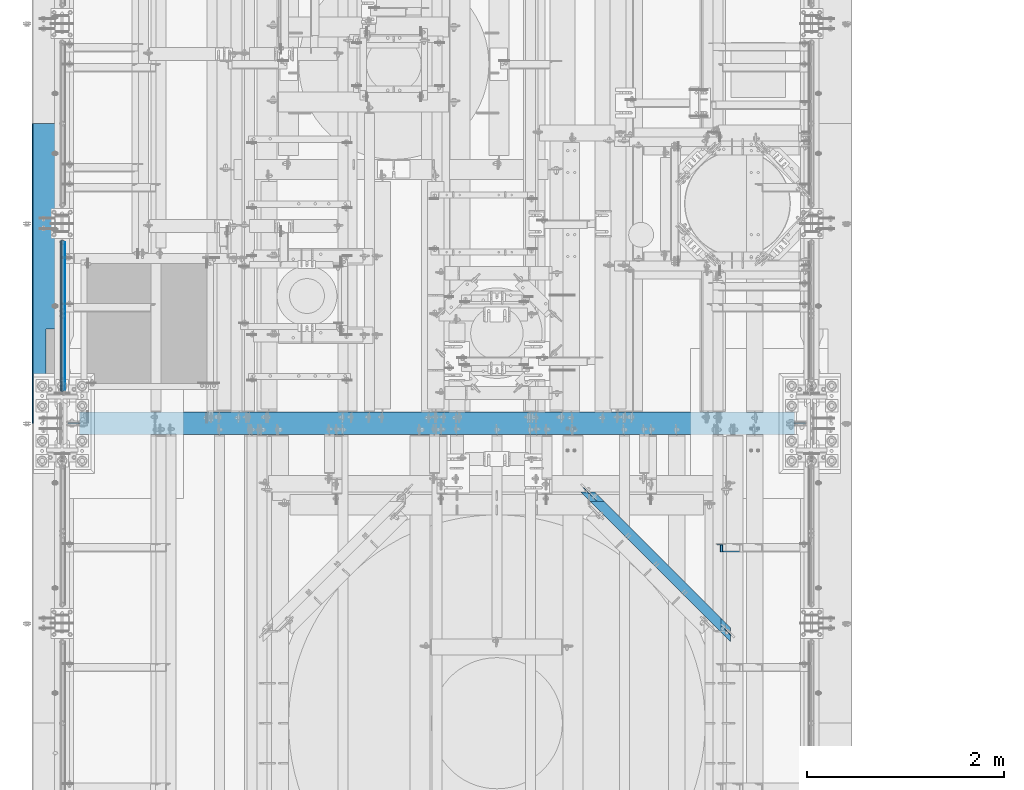
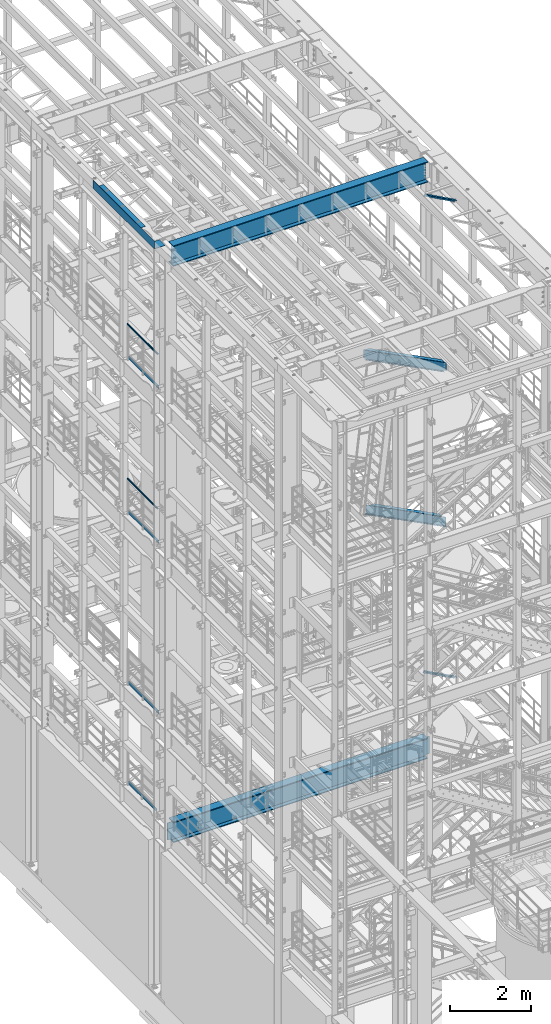
# One storey, part 1015 of 1876: 11 beams, 2 members, 11 elements without a shape of their own.
"""IFC2X3 building model written with IfcOpenShell, lengths in millimetres."""

from ifc_helpers import new_model, si_unit, frame, origin_with_axes, place, context, subcontext, project, spatial, faceted_brep, material, type_object, element, aggregate, save


model = new_model("IFC2X3")

# Units and contexts
model_context = context("Model", 3, precision=1e-05, world=origin_with_axes())
body_context = subcontext(model_context, "Body", "Model", "MODEL_VIEW")
ifc_project = project(units=[si_unit("LENGTHUNIT", "METRE", prefix="MILLI"), si_unit("AREAUNIT", "SQUARE_METRE"), si_unit("VOLUMEUNIT", "CUBIC_METRE"), si_unit("MASSUNIT", "GRAM", prefix="KILO"), si_unit("TIMEUNIT", "SECOND"), si_unit("PLANEANGLEUNIT", "RADIAN"), si_unit("SOLIDANGLEUNIT", "STERADIAN"), si_unit("THERMODYNAMICTEMPERATUREUNIT", "DEGREE_CELSIUS"), si_unit("LUMINOUSINTENSITYUNIT", "LUMEN")], contexts=[model_context])

# Site, building, storey
site_placement = place(None, origin_with_axes())
site = spatial("IfcSite", under=ifc_project, at=site_placement, CompositionType="ELEMENT")
building_placement = place(site_placement, origin_with_axes())
building = spatial("IfcBuilding", under=site, at=building_placement, Name="Undefined", CompositionType="ELEMENT")
storey_placement = place(building_placement, origin_with_axes())
storey = spatial("IfcBuildingStorey", under=building, at=storey_placement, Name="Undefined", CompositionType="ELEMENT", Elevation=0.0)

# Assembly, beam
assembly_1_placement = place(storey_placement, origin_with_axes())
assembly_1 = element("IfcElementAssembly", 1, at=assembly_1_placement, inside=storey, Name="RAIL", AssemblyPlace="NOTDEFINED", PredefinedType="RIGID_FRAME")
ifc_material_1 = material()
beam_type_1 = type_object("IfcBeamType", Name="PIPE1-1/2SCH40", PredefinedType="NOTDEFINED")
beam_1_placement = place(assembly_1_placement, frame((-1.81898940354586e-12, 1844.675, 19059.525), z_axis=(0.0, 0.0, -1.0), x_axis=(0.0, 1.0, 0.0)))
beam_1 = element("IfcBeam", 2, at=beam_1_placement, type_object=beam_type_1, material=ifc_material_1, Name="RAIL", ObjectType="PIPE1-1/2SCH40", context=body_context, shape_type="Brep", body=[
    faceted_brep([(24.1300000000001, -20.4469999999999, 0.0), (34.3535000000002, -17.7076214311803, 10.2235000000001), (1511.8715, -17.7076214311801, 10.2235000000001), (1522.095, -20.4470000000001, 0.0), (41.8376214311802, -10.2235000000001, 17.7076214311819), (1504.38737856882, -10.2235000000001, 17.7076214311819), (44.5770000000002, 0.0, 20.4470000000001), (1501.648, 0.0, 20.4470000000001), (41.8376214311802, 10.2235000000001, 17.7076214311819), (1504.38737856882, 10.2235000000001, 17.7076214311819), (34.3535000000002, 17.7076214311803, 10.2235000000001), (1511.8715, 17.7076214311801, 10.2235000000001), (24.1300000000001, 20.4469999999999, 0.0), (1522.095, 20.4470000000001, 0.0), (13.9065000000001, 17.7076214311803, -10.2235000000001), (1532.3185, 17.7076214311801, -10.2235000000001), (6.42237856882002, 10.2235000000001, -17.7076214311819), (1539.80262143118, 10.2235000000001, -17.7076214311819), (3.68299999999999, 0.0, -20.4470000000001), (1542.542, 0.0, -20.4470000000001), (6.42237856882002, -10.2235000000001, -17.7076214311819), (1539.80262143118, -10.2235000000001, -17.7076214311819), (13.9065000000001, -17.7076214311803, -10.2235000000001), (1532.3185, -17.7076214311801, -10.2235000000001), (24.1299999999854, -24.1299999999992, 0.0), (12.0650000000064, -20.8971929933177, -12.0649999999987), (1534.16, -20.8971929933186, -12.0649999999987), (1522.095, -24.1300000000001, 0.0), (3.23280700668147, -12.0650000000001, -20.8971929933177), (1542.99219299332, -12.0649999999996, -20.8971929933177), (-1.45519152283669e-11, 0.0, -24.130000000001), (1546.225, 0.0, -24.130000000001), (3.23280700668147, 12.0650000000001, -20.8971929933177), (1542.99219299332, 12.0649999999996, -20.8971929933177), (12.0650000000064, 20.8971929933177, -12.0649999999987), (1534.16, 20.8971929933186, -12.0649999999987), (24.1300000000047, 24.1299999999992, 0.0), (1522.095, 24.1300000000001, 0.0), (36.1949999999997, 20.8971929933184, 12.0649999999987), (1510.03, 20.8971929933186, 12.0649999999987), (45.0271929933187, 12.0650000000001, 20.8971929933177), (1501.19780700668, 12.0649999999996, 20.8971929933177), (48.2600000000002, 0.0, 24.130000000001), (1497.965, 0.0, 24.130000000001), (45.0271929933187, -12.0650000000001, 20.8971929933177), (1501.19780700668, -12.0649999999996, 20.8971929933177), (36.1949999999997, -20.8971929933184, 12.0649999999987), (1510.03, -20.8971929933186, 12.0649999999987)], [[[0, 1, 2, 3]], [[1, 4, 5, 2]], [[4, 6, 7, 5]], [[6, 8, 9, 7]], [[8, 10, 11, 9]], [[10, 12, 13, 11]], [[12, 14, 15, 13]], [[14, 16, 17, 15]], [[16, 18, 19, 17]], [[18, 20, 21, 19]], [[20, 22, 23, 21]], [[22, 0, 3, 23]], [[24, 25, 26, 27]], [[25, 28, 29, 26]], [[28, 30, 31, 29]], [[30, 32, 33, 31]], [[32, 34, 35, 33]], [[34, 36, 37, 35]], [[36, 38, 39, 37]], [[38, 40, 41, 39]], [[40, 42, 43, 41]], [[42, 44, 45, 43]], [[44, 46, 47, 45]], [[46, 24, 27, 47]], [[29, 31, 33, 35, 37, 39, 41, 43, 45, 47, 27, 26], [5, 7, 9, 11, 13, 15, 17, 19, 21, 23, 3, 2]], [[46, 44, 42, 40, 38, 36, 34, 32, 30, 28, 25, 24], [22, 20, 18, 16, 14, 12, 10, 8, 6, 4, 1, 0]]]),
])

assembly_2_placement = place(storey_placement, origin_with_axes())
assembly_2 = element("IfcElementAssembly", 3, at=assembly_2_placement, inside=storey, Name="RAIL", AssemblyPlace="NOTDEFINED", PredefinedType="RIGID_FRAME")
beam_2_placement = place(assembly_2_placement, frame((-1.81898940354586e-12, 1844.675, 14385.925), z_axis=(0.0, 0.0, -1.0), x_axis=(0.0, 1.0, 0.0)))
beam_2 = element("IfcBeam", 4, at=beam_2_placement, type_object=beam_type_1, material=ifc_material_1, Name="RAIL", ObjectType="PIPE1-1/2SCH40", context=body_context, shape_type="Brep", body=[
    faceted_brep([(24.1300000000001, -20.4469999999999, 0.0), (34.3535000000002, -17.7076214311803, 10.2235000000001), (1511.8715, -17.7076214311801, 10.2235000000001), (1522.095, -20.4470000000001, 0.0), (41.8376214311802, -10.2235000000001, 17.7076214311819), (1504.38737856882, -10.2235000000001, 17.7076214311819), (44.5770000000002, 0.0, 20.4470000000001), (1501.648, 0.0, 20.4470000000001), (41.8376214311802, 10.2235000000001, 17.7076214311819), (1504.38737856882, 10.2235000000001, 17.7076214311819), (34.3535000000002, 17.7076214311803, 10.2235000000001), (1511.8715, 17.7076214311801, 10.2235000000001), (24.1300000000001, 20.4469999999999, 0.0), (1522.095, 20.4470000000001, 0.0), (13.9065000000001, 17.7076214311803, -10.2235000000001), (1532.3185, 17.7076214311801, -10.2235000000001), (6.42237856882002, 10.2235000000001, -17.7076214311819), (1539.80262143118, 10.2235000000001, -17.7076214311819), (3.68299999999999, 0.0, -20.4470000000001), (1542.542, 0.0, -20.4470000000001), (6.42237856882002, -10.2235000000001, -17.7076214311819), (1539.80262143118, -10.2235000000001, -17.7076214311819), (13.9065000000001, -17.7076214311803, -10.2235000000001), (1532.3185, -17.7076214311801, -10.2235000000001), (24.1299999999854, -24.1299999999992, 0.0), (12.0650000000064, -20.8971929933177, -12.0649999999987), (1534.16, -20.8971929933186, -12.0649999999987), (1522.095, -24.1300000000001, 0.0), (3.23280700668147, -12.0650000000001, -20.8971929933177), (1542.99219299332, -12.0649999999996, -20.8971929933177), (-1.45519152283669e-11, 0.0, -24.130000000001), (1546.225, 0.0, -24.130000000001), (3.23280700668147, 12.0650000000001, -20.8971929933177), (1542.99219299332, 12.0649999999996, -20.8971929933177), (12.0650000000064, 20.8971929933177, -12.0649999999987), (1534.16, 20.8971929933186, -12.0649999999987), (24.1300000000047, 24.1299999999992, 0.0), (1522.095, 24.1300000000001, 0.0), (36.1949999999997, 20.8971929933184, 12.0649999999987), (1510.03, 20.8971929933186, 12.0649999999987), (45.0271929933187, 12.0650000000001, 20.8971929933177), (1501.19780700668, 12.0649999999996, 20.8971929933177), (48.2600000000002, 0.0, 24.130000000001), (1497.965, 0.0, 24.130000000001), (45.0271929933187, -12.0650000000001, 20.8971929933177), (1501.19780700668, -12.0649999999996, 20.8971929933177), (36.1949999999997, -20.8971929933184, 12.0649999999987), (1510.03, -20.8971929933186, 12.0649999999987)], [[[0, 1, 2, 3]], [[1, 4, 5, 2]], [[4, 6, 7, 5]], [[6, 8, 9, 7]], [[8, 10, 11, 9]], [[10, 12, 13, 11]], [[12, 14, 15, 13]], [[14, 16, 17, 15]], [[16, 18, 19, 17]], [[18, 20, 21, 19]], [[20, 22, 23, 21]], [[22, 0, 3, 23]], [[24, 25, 26, 27]], [[25, 28, 29, 26]], [[28, 30, 31, 29]], [[30, 32, 33, 31]], [[32, 34, 35, 33]], [[34, 36, 37, 35]], [[36, 38, 39, 37]], [[38, 40, 41, 39]], [[40, 42, 43, 41]], [[42, 44, 45, 43]], [[44, 46, 47, 45]], [[46, 24, 27, 47]], [[29, 31, 33, 35, 37, 39, 41, 43, 45, 47, 27, 26], [5, 7, 9, 11, 13, 15, 17, 19, 21, 23, 3, 2]], [[46, 44, 42, 40, 38, 36, 34, 32, 30, 28, 25, 24], [22, 20, 18, 16, 14, 12, 10, 8, 6, 4, 1, 0]]]),
])

# Beam
ifc_material_2 = material(Name="STEEL/A36")
beam_type_2 = type_object("IfcBeamType", PredefinedType="NOTDEFINED")
beam_3_placement = place(assembly_1_placement, frame((27.3049999999948, 1868.805, 18049.875), z_axis=(0.0, 0.0, 1.0), x_axis=(0.0, 1.0, 0.0)))
beam_3 = element("IfcBeam", 5, at=beam_3_placement, type_object=beam_type_2, material=ifc_material_2, Name="PLATE", context=body_context, shape_type="Brep", body=[
    faceted_brep([(0.0, 3.17500000000018, -50.8000000000002), (0.0, 3.17500000000018, 50.8000000000002), (1497.965, 3.175, 50.7999999999993), (1497.965, 3.175, -50.7999999999993), (0.0, -3.17500000000018, 50.8000000000002), (1497.965, -3.175, 50.7999999999993), (0.0, -3.17500000000018, -50.8000000000002), (1497.965, -3.175, -50.7999999999993)], [[[0, 1, 2, 3]], [[1, 4, 5, 2]], [[4, 6, 7, 5]], [[6, 0, 3, 7]], [[5, 7, 3, 2]], [[6, 4, 1, 0]]]),
])

aggregate(assembly_1, [beam_3, beam_1])

beam_4_placement = place(assembly_2_placement, frame((27.3049999999948, 1868.805, 13376.275), z_axis=(0.0, 0.0, 1.0), x_axis=(0.0, 1.0, 0.0)))
beam_4 = element("IfcBeam", 6, at=beam_4_placement, type_object=beam_type_2, material=ifc_material_2, Name="PLATE", context=body_context, shape_type="Brep", body=[
    faceted_brep([(0.0, 3.17500000000018, -50.8000000000002), (0.0, 3.17500000000018, 50.8000000000002), (1497.965, 3.175, 50.7999999999993), (1497.965, 3.175, -50.7999999999993), (0.0, -3.17500000000018, 50.8000000000002), (1497.965, -3.175, 50.7999999999993), (0.0, -3.17500000000018, -50.8000000000002), (1497.965, -3.175, -50.7999999999993)], [[[0, 1, 2, 3]], [[1, 4, 5, 2]], [[4, 6, 7, 5]], [[6, 0, 3, 7]], [[5, 7, 3, 2]], [[6, 4, 1, 0]]]),
])

aggregate(assembly_2, [beam_4, beam_2])

# Assembly, beam
assembly_3_placement = place(storey_placement, origin_with_axes())
assembly_3 = element("IfcElementAssembly", 7, at=assembly_3_placement, inside=storey, Name="RAIL", AssemblyPlace="NOTDEFINED", PredefinedType="RIGID_FRAME")
beam_5_placement = place(assembly_3_placement, frame((27.3049999999948, 1868.805, 8220.07500000001), z_axis=(0.0, 0.0, 1.0), x_axis=(0.0, 1.0, 0.0)))
beam_5 = element("IfcBeam", 8, at=beam_5_placement, type_object=beam_type_2, material=ifc_material_2, Name="PLATE", context=body_context, shape_type="Brep", body=[
    faceted_brep([(0.0, 3.17500000000018, -50.8000000000002), (0.0, 3.17500000000018, 50.8000000000002), (1497.965, 3.175, 50.7999999999993), (1497.965, 3.175, -50.7999999999993), (0.0, -3.17500000000018, 50.8000000000002), (1497.965, -3.175, 50.7999999999993), (0.0, -3.17500000000018, -50.8000000000002), (1497.965, -3.175, -50.7999999999993)], [[[0, 1, 2, 3]], [[1, 4, 5, 2]], [[4, 6, 7, 5]], [[6, 0, 3, 7]], [[5, 7, 3, 2]], [[6, 4, 1, 0]]]),
])
aggregate(assembly_3, [beam_5])

assembly_4_placement = place(storey_placement, origin_with_axes())
assembly_4 = element("IfcElementAssembly", 9, at=assembly_4_placement, inside=storey, Name="RAIL", AssemblyPlace="NOTDEFINED", PredefinedType="RIGID_FRAME")
beam_6_placement = place(assembly_4_placement, frame((27.3049999999948, 1964.05499999999, 5197.475), z_axis=(0.0, 0.0, 1.0), x_axis=(0.0, 1.0, 0.0)))
beam_6 = element("IfcBeam", 10, at=beam_6_placement, type_object=beam_type_2, material=ifc_material_2, Name="PLATE", context=body_context, shape_type="Brep", body=[
    faceted_brep([(0.0, 3.17500000000018, -50.8000000000002), (0.0, 3.17500000000018, 50.8000000000002), (1402.715, 3.175, 50.8000000000002), (1402.715, 3.175, -50.8000000000002), (0.0, -3.17500000000018, 50.8000000000002), (1402.715, -3.175, 50.8000000000002), (0.0, -3.17500000000018, -50.8000000000002), (1402.715, -3.175, -50.8000000000002)], [[[0, 1, 2, 3]], [[1, 4, 5, 2]], [[4, 6, 7, 5]], [[6, 0, 3, 7]], [[5, 7, 3, 2]], [[6, 4, 1, 0]]]),
])
aggregate(assembly_4, [beam_6])

# Assembly, member
assembly_5_placement = place(storey_placement, origin_with_axes())
assembly_5 = element("IfcElementAssembly", 11, at=assembly_5_placement, inside=storey, AssemblyPlace="NOTDEFINED", PredefinedType="RIGID_FRAME")
member_type = type_object("IfcMemberType", Name="L3X3X3/8", PredefinedType="NOTDEFINED")
member_1_placement = place(assembly_5_placement, frame((6613.42656309324, 257.174999999997, 8122.54466495056), z_axis=(0.0, -1.0, 0.0), x_axis=(0.882670061850832, 0.0, -0.469993150920573)))
member_1 = element("IfcMember", 12, at=member_1_placement, type_object=member_type, material=ifc_material_2, ObjectType="L3X3X3/8", context=body_context, shape_type="Brep", body=[
    faceted_brep([(70.0788597189262, 38.1000000000258, -38.1), (70.0788597189262, 38.1000000000258, 38.1), (1091.31003699859, 38.1000000003387, 38.1), (1091.31003699859, 38.1000000003387, -38.1), (70.0788597189253, 28.5750000000244, 38.1), (1091.31003699859, 28.5750000003391, 38.1), (70.0788597189253, 28.5750000000244, -28.575), (1091.31003699859, 28.5750000003391, -28.575), (70.0788597189262, -38.0999999999822, -28.575), (1091.31003699859, -38.0999999996675, -28.575), (70.0788597189262, -38.0999999999822, -38.1), (1091.31003699859, -38.0999999996675, -38.1)], [[[0, 1, 2, 3]], [[1, 4, 5, 2]], [[4, 6, 7, 5]], [[6, 8, 9, 7]], [[8, 10, 11, 9]], [[10, 0, 3, 11]], [[5, 7, 9, 11, 3, 2]], [[10, 8, 6, 4, 1, 0]]]),
])
aggregate(assembly_5, [member_1])

assembly_6_placement = place(storey_placement, origin_with_axes())
assembly_6 = element("IfcElementAssembly", 13, at=assembly_6_placement, inside=storey, AssemblyPlace="NOTDEFINED", PredefinedType="RIGID_FRAME")
member_2_placement = place(assembly_6_placement, frame((6649.22451200435, 257.174999999997, 22521.7692276093), z_axis=(0.0, -1.0, 0.0), x_axis=(0.877448093107094, 0.0, -0.479671600058544)))
member_2 = element("IfcMember", 14, at=member_2_placement, type_object=member_type, material=ifc_material_2, ObjectType="L3X3X3/8", context=body_context, shape_type="Brep", body=[
    faceted_brep([(59.7482362440578, 38.0999999998749, -38.0999999999999), (59.7482362440578, 38.0999999998749, 38.0999999999999), (1062.91900040893, 38.0999999984488, 38.0999999999999), (1062.91900040893, 38.0999999984488, -38.0999999999999), (59.7482362440696, 28.5749999998843, 38.0999999999999), (1062.91900040895, 28.5749999984582, 38.0999999999999), (59.7482362440696, 28.5749999998843, -28.5749999999998), (1062.91900040895, 28.5749999984582, -28.5749999999998), (59.7482362441442, -38.1000000000495, -28.5749999999998), (1062.91900040902, -38.1000000014719, -28.5749999999998), (59.7482362441442, -38.1000000000495, -38.0999999999999), (1062.91900040902, -38.1000000014719, -38.0999999999999)], [[[0, 1, 2, 3]], [[1, 4, 5, 2]], [[4, 6, 7, 5]], [[6, 8, 9, 7]], [[8, 10, 11, 9]], [[10, 0, 3, 11]], [[5, 7, 9, 11, 3, 2]], [[10, 8, 6, 4, 1, 0]]]),
])
aggregate(assembly_6, [member_2])

# Assembly, beam
assembly_7_placement = place(storey_placement, origin_with_axes())
assembly_7 = element("IfcElementAssembly", 15, at=assembly_7_placement, inside=storey, Name="BEAM", AssemblyPlace="NOTDEFINED", PredefinedType="RIGID_FRAME")
ifc_material_3 = material(Name="STEEL/A992")
beam_type_3 = type_object("IfcBeamType", Name="W12X16", PredefinedType="NOTDEFINED")
beam_7_placement = place(assembly_7_placement, frame((6903.48911505469, -731.547206052242, 17830.8), z_axis=(0.0, 0.0, 1.0), x_axis=(-0.707106781186548, 0.707106781186547, 0.0)))
beam_7 = element("IfcBeam", 16, at=beam_7_placement, type_object=beam_type_3, material=ifc_material_3, Name="BEAM", ObjectType="W12X16", context=body_context, shape_type="Brep", body=[
    faceted_brep([(175.17619927822, 50.7999999999511, -152.400000000001), (175.17619927822, 50.7999999999511, -146.049999999999), (2239.32686272223, 50.7999999995645, -146.049999999999), (2239.32686272223, 50.7999999995645, -152.400000000001), (222.801200490549, 3.17499999995653, -146.049999999999), (2191.70186393459, 3.17499999958818, -146.049999999999), (2209.66237567833, 3.17499999958545, -131.762500000008), (2203.31237583998, -3.17500000041218, -131.762500000008), (2196.43918555883, -3.17500000041036, -132.729229922596), (2202.78918539718, 3.17499999958545, -132.729229922596), (2190.61237619236, -3.17500000040945, -135.482243823073), (2196.96237603071, 3.17499999958727, -135.482243823073), (2186.71902664645, -3.17500000040855, -139.602420291227), (2193.06902648481, 3.17499999958818, -139.602420291227), (2185.35186409618, -3.17500000040855, -144.462499809273), (2191.70186393453, 3.17499999958818, -144.462499809273), (229.151200652193, -3.17500000004202, -146.049999999999), (276.776201864521, -50.8000000000366, -146.049999999999), (2137.7268653086, -50.8000000003849, -146.049999999999), (2185.35186409624, -3.17500000040855, -146.049999999999), (276.776201864521, -50.8000000000366, -152.400000000001), (2137.7268653086, -50.8000000003849, -152.400000000001), (229.151200652176, -3.17500000004293, -144.46249980927), (222.80120049053, 3.17499999995653, -144.46249980927), (227.7840380671, -3.17500000004202, -139.602420291223), (221.434037905454, 3.17499999995653, -139.602420291223), (223.89068842209, -3.17500000004202, -135.482243823069), (217.540688260444, 3.17499999995744, -135.482243823069), (218.063878907296, -3.17500000004111, -132.729229922592), (211.713878745652, 3.17499999995835, -132.729229922592), (211.190688451187, -3.1750000000402, -131.762500000004), (204.840688289542, 3.17499999996016, -131.762500000004), (142.297997710428, -3.17499999997381, -131.762500000004), (142.297997710437, 3.17500000002565, -131.762500000004), (142.297997710428, -3.17499999997381, 123.825000000001), (142.297997710437, 3.17500000002565, 123.825000000001), (211.190688450936, -3.1750000000402, 123.825000000001), (204.840688289291, 3.17499999996016, 123.825000000001), (218.063878907045, -3.17500000004111, 124.791729922588), (211.713878745401, 3.17499999995835, 124.791729922588), (223.890688421839, -3.17500000004202, 127.544743823066), (217.540688260193, 3.17499999995744, 127.544743823066), (227.784038066849, -3.17500000004202, 131.664920291219), (221.434037905203, 3.17499999995653, 131.664920291219), (229.151200651925, -3.17500000004293, 136.524999809266), (222.801200490279, 3.17499999995653, 136.524999809266), (2239.32686272236, 50.7999999995645, 152.400000000001), (2239.32686272236, 50.7999999995645, 146.049999999999), (175.176199277891, 50.7999999999502, 146.049999999999), (175.176199277891, 50.7999999999502, 152.400000000001), (2137.72686530873, -50.8000000003849, 152.400000000001), (276.776201864192, -50.8000000000366, 152.400000000001), (2137.72686530873, -50.8000000003849, 146.049999999999), (276.776201864192, -50.8000000000366, 146.049999999999), (2185.35186409637, -3.17500000040855, 146.049999999999), (229.151200651863, -3.17500000004202, 146.049999999999), (222.801200490219, 3.17499999995653, 146.049999999999), (2191.70186393472, 3.17499999958818, 146.049999999999), (2185.35186409639, -3.17500000040764, 136.524999809262), (2191.70186393474, 3.17499999958818, 136.524999809262), (2186.71902664666, -3.17500000040855, 131.664920291216), (2193.06902648501, 3.17499999958727, 131.664920291216), (2190.61237619256, -3.17500000040945, 127.544743823062), (2196.96237603092, 3.17499999958727, 127.544743823062), (2196.43918555903, -3.17500000041036, 124.791729922585), (2202.78918539739, 3.17499999958636, 124.791729922585), (2203.31237584018, -3.17500000041218, 123.824999999997), (2209.66237567854, 3.17499999958454, 123.824999999997), (2272.20506418067, -3.17500000042401, 123.824999999997), (2272.20506418067, 3.17499999957363, 123.824999999997), (2272.20506418067, 3.17499999957363, -131.762500000008), (2272.20506418067, -3.17500000042401, -131.762500000008)], [[[0, 1, 2, 3]], [[1, 4, 5, 2]], [[6, 7, 8, 9]], [[9, 8, 10, 11]], [[11, 10, 12, 13]], [[13, 12, 14, 15]], [[16, 17, 18, 19]], [[17, 20, 21, 18]], [[2, 5, 15, 14, 19, 18, 21, 3]], [[20, 0, 3, 21]], [[17, 16, 22, 23, 4, 1, 0, 20]], [[24, 25, 23, 22]], [[26, 27, 25, 24]], [[28, 29, 27, 26]], [[30, 31, 29, 28]], [[31, 30, 32, 33]], [[33, 32, 34, 35]], [[36, 37, 35, 34]], [[38, 39, 37, 36]], [[40, 41, 39, 38]], [[42, 43, 41, 40]], [[44, 45, 43, 42]], [[46, 47, 48, 49]], [[50, 46, 49, 51]], [[52, 50, 51, 53]], [[54, 52, 53, 55]], [[51, 49, 48, 56, 45, 44, 55, 53]], [[47, 57, 56, 48]], [[46, 50, 52, 54, 58, 59, 57, 47]], [[59, 58, 60, 61]], [[61, 60, 62, 63]], [[63, 62, 64, 65]], [[65, 64, 66, 67]], [[67, 66, 68, 69]], [[6, 9, 11, 13, 15, 5, 4, 23, 25, 27, 29, 31, 33, 35, 37, 39, 41, 43, 45, 56, 57, 59, 61, 63, 65, 67, 69, 70]], [[7, 6, 70, 71]], [[66, 64, 62, 60, 58, 54, 55, 44, 42, 40, 38, 36, 34, 32, 30, 28, 26, 24, 22, 16, 19, 14, 12, 10, 8, 7, 71, 68]], [[70, 69, 68, 71]]]),
])
aggregate(assembly_7, [beam_7])

assembly_8_placement = place(storey_placement, origin_with_axes())
assembly_8 = element("IfcElementAssembly", 17, at=assembly_8_placement, inside=storey, Name="BEAM", AssemblyPlace="NOTDEFINED", PredefinedType="RIGID_FRAME")
beam_8_placement = place(assembly_8_placement, frame((5535.90610564896, 636.291142976258, 13157.2), z_axis=(0.0, 0.0, 1.0), x_axis=(0.707106781186547, -0.707106781186548, 0.0)))
beam_8 = element("IfcBeam", 18, at=beam_8_placement, type_object=beam_type_3, material=ifc_material_3, Name="BEAM", ObjectType="W12X16", context=body_context, shape_type="Brep", body=[
    faceted_brep([(1696.01646575654, -50.7999999994199, 152.4), (1696.01646575654, -50.7999999994199, 146.049999999999), (1648.39147936165, -3.17499999944266, 146.049999999999), (1648.39147936148, -3.17499999944266, 128.587499808526), (1642.04148117549, 3.17500000055406, 128.587499808526), (1642.04148117567, 3.17500000055406, 146.049999999999), (1594.41649478078, 50.8000000005313, 146.049999999999), (1594.41649478078, 50.8000000005313, 152.4), (1649.75864173388, -3.17499999944175, 123.727420290479), (1643.40864354789, 3.17500000055406, 123.727420290479), (1653.65199077323, -3.17499999944084, 119.607243822325), (1647.30199258724, 3.17500000055588, 119.607243822325), (1659.47879938159, -3.17499999943993, 116.854229921848), (1653.1288011956, 3.17500000055679, 116.854229921848), (1666.35198876849, -3.1749999994363, 115.88749999926), (1660.0019905825, 3.17500000056043, 115.88749999926), (1786.46289533344, -3.17499999939628, 115.88749999926), (1780.11289714745, 3.17500000060045, 115.88749999926), (-82.0778965322579, 50.7999999999847, 152.4), (-82.0778965322579, 50.7999999999847, 146.049999999999), (-129.702910137345, 3.17499999998699, 146.049999999999), (-129.702910137345, 3.17499999998699, 128.587499809264), (-136.052911951358, -3.17500000001246, 128.587499809264), (-136.052911951358, -3.17500000001246, 146.049999999999), (-183.677925556445, -50.8000000000102, 146.049999999999), (-183.677925556445, -50.8000000000102, 152.4), (-131.0700729003, 3.17499999998699, 123.727420291218), (-137.420074714312, -3.17500000001291, 123.727420291218), (-134.963423051866, 3.17499999998699, 119.607243823064), (-141.313424865878, -3.17500000001291, 119.607243823064), (-140.790233324775, 3.17499999998608, 116.854229922586), (-147.140235138787, -3.17500000001382, 116.854229922586), (-147.663424675142, 3.17499999998518, 115.887499999999), (-154.013426489153, -3.17500000001473, 115.887499999999), (-267.774365563642, 3.17499999997335, 115.887499999999), (-274.124367377653, -3.17500000002656, 115.887499999999), (-267.774365563642, 3.17499999997335, -146.049999999999), (-220.149351958555, 50.7999999999711, -146.049999999999), (-220.149351958555, 50.7999999999711, -152.4), (-321.749380982741, -50.8000000000243, -152.4), (-321.749380982741, -50.8000000000243, -146.049999999999), (-274.124367377653, -3.17500000002656, -146.049999999999), (1780.11289714745, 3.17500000060045, -146.049999999999), (1732.48791075252, 50.8000000005786, -146.049999999999), (1732.48791075252, 50.8000000005786, -152.4), (1834.08788172837, -50.7999999993735, -152.4), (1834.08788172837, -50.7999999993735, -146.049999999999), (1786.46289533344, -3.17499999939628, -146.049999999999)], [[[0, 1, 2, 3, 4, 5, 6, 7]], [[8, 9, 4, 3]], [[10, 11, 9, 8]], [[12, 13, 11, 10]], [[14, 15, 13, 12]], [[16, 17, 15, 14]], [[18, 19, 20, 21, 22, 23, 24, 25]], [[26, 27, 22, 21]], [[28, 29, 27, 26]], [[30, 31, 29, 28]], [[32, 33, 31, 30]], [[34, 35, 33, 32]], [[36, 37, 38, 39, 40, 41, 35, 34]], [[37, 36, 42, 43]], [[38, 37, 43, 44]], [[39, 38, 44, 45]], [[40, 39, 45, 46]], [[41, 40, 46, 47]], [[12, 10, 8, 3, 2, 23, 22, 27, 29, 31, 33, 35, 41, 47, 16, 14]], [[24, 23, 2, 1]], [[25, 24, 1, 0]], [[18, 25, 0, 7]], [[19, 18, 7, 6]], [[20, 19, 6, 5]], [[42, 36, 34, 32, 30, 28, 26, 21, 20, 5, 4, 9, 11, 13, 15, 17]], [[47, 46, 45, 44, 43, 42, 17, 16]]]),
])
aggregate(assembly_8, [beam_8])

assembly_9_placement = place(storey_placement, origin_with_axes())
assembly_9 = element("IfcElementAssembly", 19, at=assembly_9_placement, inside=storey, Name="BENT PLATE", AssemblyPlace="NOTDEFINED", PredefinedType="RIGID_FRAME")
beam_type_4 = type_object("IfcBeamType", PredefinedType="NOTDEFINED")
beam_9_placement = place(assembly_9_placement, frame((2.28578142867657e-05, 3048.0, 22558.3750000001), z_axis=(0.0, 1.0, 0.0), x_axis=(-0.999999999968684, 0.0, -7.91400000071008e-06)))
beam_9 = element("IfcBeam", 20, at=beam_9_placement, type_object=beam_type_4, material=ifc_material_2, Name="BENT PLATE", context=body_context, shape_type="Brep", body=[
    faceted_brep([(165.100051822637, -3.17500005134207, -1235.07496680687), (165.100006108988, 3.17499994866375, -1235.07495110332), (9.87827514231654e-10, 3.17499999999927, -1235.07495110038), (-9.87827486476078e-10, -3.17500000000291, -1235.07496680393), (165.100051822637, -3.17500005134207, -561.97499121896), (165.100006108988, 3.17499994866375, -561.974975515408), (-9.87827486476078e-10, -3.17500000000291, -561.97499121602), (9.87827514231654e-10, 3.17499999999927, -561.974975512469), (304.799984389467, -3.1750000948341, 1524.0), (304.799984389467, -3.1750000948341, -1524.0), (304.798604036541, 236.934982372881, -1524.0), (304.798604036052, 236.934982372997, 1524.0), (298.449951181141, 3.17499990714714, 1524.0), (-9.88620740827173e-10, 3.17500000000291, 1524.0), (9.877112461254e-10, -3.17499999999563, 1524.0), (298.448604036157, 236.934945778325, 1524.0), (298.449951181141, 3.17499990714714, -1524.0), (298.448604036646, 236.934945778212, -1524.0), (9.877112461254e-10, -3.17499999999563, -1524.0), (-9.88620740827173e-10, 3.17500000000291, -1524.0)], [[[0, 1, 2, 3]], [[4, 5, 1, 0]], [[6, 7, 5, 4]], [[8, 9, 10, 11]], [[12, 13, 14, 8, 11, 15]], [[16, 12, 15, 17]], [[11, 10, 17, 15]], [[9, 18, 19, 16, 17, 10]], [[19, 18, 3, 2]], [[13, 12, 16, 19, 2, 1, 5, 7]], [[14, 13, 7, 6]], [[3, 18, 9, 8, 14, 6, 4, 0]]]),
])
aggregate(assembly_9, [beam_9])

assembly_10_placement = place(storey_placement, origin_with_axes())
assembly_10 = element("IfcElementAssembly", 21, at=assembly_10_placement, inside=storey, Name="BEAM", AssemblyPlace="NOTDEFINED", PredefinedType="RIGID_FRAME")
beam_type_5 = type_object("IfcBeamType", Name="W24X103", PredefinedType="NOTDEFINED")
beam_10_placement = place(assembly_10_placement, frame((0.0, 1524.0, 22244.05), z_axis=(0.0, 0.0, 1.0), x_axis=(1.0, 0.0, 0.0)))
beam_10 = element("IfcBeam", 22, at=beam_10_placement, type_object=beam_type_5, material=ifc_material_3, Name="BEAM", ObjectType="W24X103", context=body_context, shape_type="Brep", body=[
    faceted_brep([(171.45, 114.3, -311.150000000001), (171.45, 114.3, -285.75), (7448.55, 114.3, -285.75), (7448.55, 114.3, -311.150000000001), (171.45, 7.14374999999995, -285.75), (7448.55, 7.14374999999995, -285.75), (171.45, 7.14374999999995, 285.75), (7448.55, 7.14374999999995, 285.75), (171.45, 114.3, 285.75), (7448.55, 114.3, 285.75), (171.45, 114.3, 311.150000000001), (7448.55, 114.3, 311.150000000001), (171.45, -114.3, 311.150000000001), (7448.55, -114.3, 311.150000000001), (171.45, -114.3, 285.75), (7448.55, -114.3, 285.75), (171.45, -7.14374999999995, 285.75), (7448.55, -7.14374999999995, 285.75), (171.45, -7.14374999999995, -285.75), (7448.55, -7.14374999999995, -285.75), (171.45, -114.3, -285.75), (7448.55, -114.3, -285.75), (171.45, -114.3, -311.150000000001), (7448.55, -114.3, -311.150000000001)], [[[0, 1, 2, 3]], [[1, 4, 5, 2]], [[4, 6, 7, 5]], [[6, 8, 9, 7]], [[8, 10, 11, 9]], [[10, 12, 13, 11]], [[12, 14, 15, 13]], [[14, 16, 17, 15]], [[16, 18, 19, 17]], [[18, 20, 21, 19]], [[20, 22, 23, 21]], [[22, 0, 3, 23]], [[5, 7, 9, 11, 13, 15, 17, 19, 21, 23, 3, 2]], [[22, 20, 18, 16, 14, 12, 10, 8, 6, 4, 1, 0]]]),
])
aggregate(assembly_10, [beam_10])

assembly_11_placement = place(storey_placement, origin_with_axes())
assembly_11 = element("IfcElementAssembly", 23, at=assembly_11_placement, inside=storey, Name="BEAM", AssemblyPlace="NOTDEFINED", PredefinedType="RIGID_FRAME")
beam_11_placement = place(assembly_11_placement, frame((0.0, 1524.0, 4819.65), z_axis=(0.0, 0.0, 1.0), x_axis=(1.0, 0.0, 0.0)))
beam_11 = element("IfcBeam", 24, at=beam_11_placement, type_object=beam_type_5, material=ifc_material_3, Name="BEAM", ObjectType="W24X103", context=body_context, shape_type="Brep", body=[
    faceted_brep([(7443.7875, -7.14374999999995, -285.75), (7443.7875, -114.3, -285.75), (7443.7875, -114.3, -311.15), (7443.7875, 114.3, -311.15), (7443.7875, 114.3, -285.75), (7443.7875, 7.14374999999995, -285.75), (7443.7875, 7.14374999999995, -273.049999809265), (7443.7875, -7.14374999999995, -273.049999809265), (7444.75422992259, 7.14374999999995, -268.189920291219), (7444.75422992259, -7.14374999999995, -268.189920291219), (7447.50724382307, 7.14374999999995, -264.069743823065), (7447.50724382307, -7.14374999999995, -264.069743823065), (7451.62742029122, 7.14374999999995, -261.316729922587), (7451.62742029122, -7.14374999999995, -261.316729922587), (7456.48749980927, 7.14374999999995, -260.349999999999), (7456.48749980927, -7.14374999999995, -260.349999999999), (7558.0875, -7.14374999999995, -260.349999999999), (7558.0875, 7.14374999999995, -260.349999999999), (176.2125, 7.14374999999995, 285.75), (176.2125, 114.3, 285.75), (7443.7875, 114.3, 285.75), (7443.7875, 7.14374999999995, 285.75), (176.2125, -7.14374999999995, -273.049999809265), (176.2125, 7.14374999999995, -273.049999809265), (176.2125, 7.14374999999995, -285.75), (176.2125, 114.3, -285.75), (176.2125, 114.3, -311.15), (176.2125, -114.3, -311.15), (176.2125, -114.3, -285.75), (176.2125, -7.14374999999995, -285.75), (175.245770077412, -7.14374999999995, -268.189920291219), (175.245770077412, 7.14374999999995, -268.189920291219), (172.492756176934, -7.14374999999995, -264.069743823065), (172.492756176934, 7.14374999999995, -264.069743823065), (168.37257970878, -7.14374999999995, -261.316729922587), (168.37257970878, 7.14374999999995, -261.316729922587), (163.512500190734, -7.14374999999995, -260.349999999999), (163.512500190734, 7.14374999999995, -260.349999999999), (61.9125000000001, -7.14374999999995, -260.349999999999), (61.9125000000001, 7.14374999999995, -260.349999999999), (61.9125000000001, -7.14374999999995, 260.35), (61.9125000000001, 7.14374999999995, 260.35), (163.512500190734, -7.14374999999995, 260.35), (163.512500190734, 7.14374999999995, 260.35), (168.37257970878, -7.14374999999995, 261.316729922588), (168.37257970878, 7.14374999999995, 261.316729922588), (172.492756176934, -7.14374999999995, 264.069743823066), (172.492756176934, 7.14374999999995, 264.069743823066), (175.245770077412, -7.14374999999995, 268.18992029122), (175.245770077412, 7.14374999999995, 268.18992029122), (176.2125, -7.14374999999995, 273.049999809266), (176.2125, 7.14374999999995, 273.049999809266), (176.2125, -114.3, 311.15), (176.2125, 114.3, 311.15), (176.2125, -7.14374999999995, 285.75), (176.2125, -114.3, 285.75), (7443.7875, -7.14374999999995, 285.75), (7443.7875, -114.3, 285.75), (7443.7875, -114.3, 311.15), (7443.7875, 114.3, 311.15), (7443.7875, -7.14374999999995, 273.049999809266), (7443.7875, 7.14374999999995, 273.049999809266), (7444.75422992259, -7.14374999999995, 268.18992029122), (7444.75422992259, 7.14374999999995, 268.18992029122), (7447.50724382307, -7.14374999999995, 264.069743823066), (7447.50724382307, 7.14374999999995, 264.069743823066), (7451.62742029122, -7.14374999999995, 261.316729922588), (7451.62742029122, 7.14374999999995, 261.316729922588), (7456.48749980927, -7.14374999999995, 260.35), (7456.48749980927, 7.14374999999995, 260.35), (7558.0875, -7.14374999999995, 260.35), (7558.0875, 7.14374999999995, 260.35)], [[[0, 1, 2, 3, 4, 5, 6, 7]], [[7, 6, 8, 9]], [[9, 8, 10, 11]], [[11, 10, 12, 13]], [[13, 12, 14, 15]], [[16, 15, 14, 17]], [[18, 19, 20, 21]], [[22, 23, 24, 25, 26, 27, 28, 29]], [[30, 31, 23, 22]], [[32, 33, 31, 30]], [[34, 35, 33, 32]], [[36, 37, 35, 34]], [[38, 39, 37, 36]], [[40, 41, 39, 38]], [[42, 43, 41, 40]], [[44, 45, 43, 42]], [[46, 47, 45, 44]], [[48, 49, 47, 46]], [[50, 51, 49, 48]], [[52, 53, 19, 18, 51, 50, 54, 55]], [[55, 54, 56, 57]], [[52, 55, 57, 58]], [[53, 52, 58, 59]], [[19, 53, 59, 20]], [[58, 57, 56, 60, 61, 21, 20, 59]], [[62, 63, 61, 60]], [[64, 65, 63, 62]], [[66, 67, 65, 64]], [[68, 69, 67, 66]], [[70, 71, 69, 68]], [[71, 70, 16, 17]], [[12, 10, 8, 6, 5, 24, 23, 31, 33, 35, 37, 39, 41, 43, 45, 47, 49, 51, 18, 21, 61, 63, 65, 67, 69, 71, 17, 14]], [[25, 24, 5, 4]], [[26, 25, 4, 3]], [[27, 26, 3, 2]], [[28, 27, 2, 1]], [[29, 28, 1, 0]], [[70, 68, 66, 64, 62, 60, 56, 54, 50, 48, 46, 44, 42, 40, 38, 36, 34, 32, 30, 22, 29, 0, 7, 9, 11, 13, 15, 16]]]),
])
aggregate(assembly_11, [beam_11])

save(model, "model.ifc")
